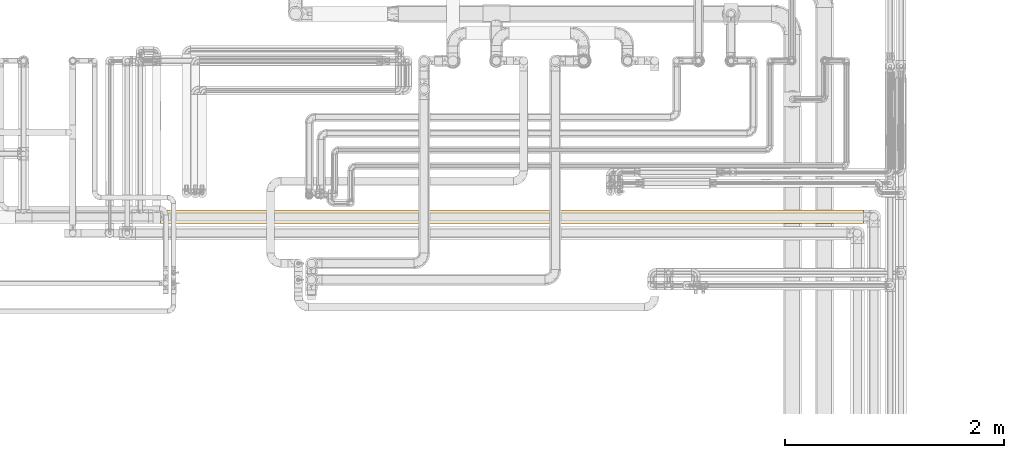
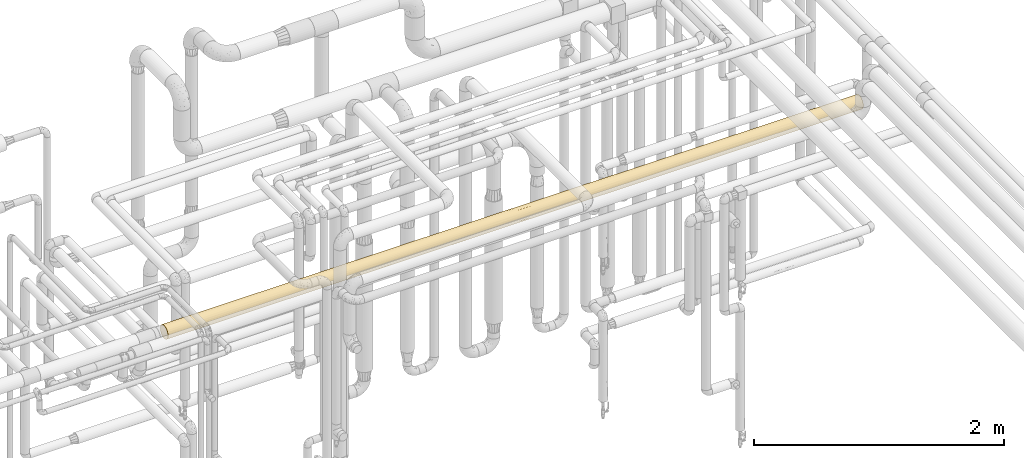
# One storey, part 47 of 827: 1 covering.
"""IFC2X3 building model written with IfcOpenShell, lengths in millimetres."""

from ifc_helpers import new_model, entity, si_unit, converted_unit, derived_unit, direction, frame, origin, place, context, subcontext, project, spatial, faceted_brep, element, save


model = new_model("IFC2X3")

# Units and contexts
model_context = context("Model", 3, precision=0.01, world=origin(), true_north=direction((6.12303176911189e-17, 1.0)))
body_context = subcontext(model_context, "Body", "Model", "MODEL_VIEW")
ifc_project = project(units=[si_unit("LENGTHUNIT", "METRE", prefix="MILLI"), si_unit("AREAUNIT", "SQUARE_METRE"), si_unit("VOLUMEUNIT", "CUBIC_METRE"), converted_unit("PLANEANGLEUNIT", "DEGREE", entity("IfcRatioMeasure", 0.0174532925199433), si_unit("PLANEANGLEUNIT", "RADIAN"), dimensions=[0, 0, 0, 0, 0, 0, 0]), si_unit("MASSUNIT", "GRAM", prefix="KILO"), derived_unit("MASSDENSITYUNIT", [(si_unit("MASSUNIT", "GRAM", prefix="KILO"), 1), (si_unit("LENGTHUNIT", "METRE"), -3)]), derived_unit("MOMENTOFINERTIAUNIT", [(si_unit("LENGTHUNIT", "METRE"), 4)]), si_unit("TIMEUNIT", "SECOND"), si_unit("FREQUENCYUNIT", "HERTZ"), si_unit("THERMODYNAMICTEMPERATUREUNIT", "DEGREE_CELSIUS"), derived_unit("THERMALTRANSMITTANCEUNIT", [(si_unit("MASSUNIT", "GRAM", prefix="KILO"), 1), (si_unit("THERMODYNAMICTEMPERATUREUNIT", "KELVIN"), -1), (si_unit("TIMEUNIT", "SECOND"), -3)]), derived_unit("VOLUMETRICFLOWRATEUNIT", [(si_unit("LENGTHUNIT", "METRE"), 3), (si_unit("TIMEUNIT", "SECOND"), -1)]), derived_unit("MASSFLOWRATEUNIT", [(si_unit("MASSUNIT", "GRAM", prefix="KILO"), 1), (si_unit("TIMEUNIT", "SECOND"), -1)]), derived_unit("ROTATIONALFREQUENCYUNIT", [(si_unit("TIMEUNIT", "SECOND"), -1)]), si_unit("ELECTRICCURRENTUNIT", "AMPERE"), si_unit("ELECTRICVOLTAGEUNIT", "VOLT"), si_unit("POWERUNIT", "WATT"), si_unit("FORCEUNIT", "NEWTON", prefix="KILO"), si_unit("ILLUMINANCEUNIT", "LUX"), si_unit("LUMINOUSFLUXUNIT", "LUMEN"), si_unit("LUMINOUSINTENSITYUNIT", "CANDELA"), derived_unit("USERDEFINED", [(si_unit("MASSUNIT", "GRAM", prefix="KILO"), -1), (si_unit("LENGTHUNIT", "METRE"), -2), (si_unit("TIMEUNIT", "SECOND"), 3), (si_unit("LUMINOUSFLUXUNIT", "LUMEN"), 1)]), derived_unit("LINEARVELOCITYUNIT", [(si_unit("LENGTHUNIT", "METRE"), 1), (si_unit("TIMEUNIT", "SECOND"), -1)]), si_unit("PRESSUREUNIT", "PASCAL"), derived_unit("USERDEFINED", [(si_unit("LENGTHUNIT", "METRE"), -2), (si_unit("MASSUNIT", "GRAM", prefix="KILO"), 1), (si_unit("TIMEUNIT", "SECOND"), -2)]), derived_unit("LINEARFORCEUNIT", [(si_unit("MASSUNIT", "GRAM", prefix="KILO"), 1), (si_unit("LENGTHUNIT", "METRE"), 1), (si_unit("TIMEUNIT", "SECOND"), -2), (si_unit("LENGTHUNIT", "METRE"), -1)]), derived_unit("PLANARFORCEUNIT", [(si_unit("MASSUNIT", "GRAM", prefix="KILO"), 1), (si_unit("LENGTHUNIT", "METRE"), 1), (si_unit("TIMEUNIT", "SECOND"), -2), (si_unit("LENGTHUNIT", "METRE"), -2)])], contexts=[model_context])

# Site, building, storey
site_placement = place(None, origin())
site = spatial("IfcSite", under=ifc_project, at=site_placement, CompositionType="ELEMENT")
building_placement = place(site_placement, origin())
building = spatial("IfcBuilding", under=site, at=building_placement, CompositionType="ELEMENT")
storey_placement = place(building_placement, frame((0.0, 0.0, 28200.0)))
storey = spatial("IfcBuildingStorey", under=building, at=storey_placement, Name="08", CompositionType="ELEMENT", Elevation=28200.0)

# Covering
covering_placement = place(storey_placement, frame((54373.19, 16008.03, 2635.69)))
element("IfcCovering", 1, at=covering_placement, inside=storey, Name=":ADSK_", ObjectType=":ADSK_", PredefinedType="INSULATION", context=body_context, shape_type="Brep", body=[
    faceted_brep([(1.6, 10.0, 32.97), (1.6, 3.73, 48.1), (1.6, 1.6, 64.35), (1.6, 3.73, 80.59), (1.6, 10.0, 95.72), (1.6, 19.97, 108.72), (1.6, 32.97, 118.69), (1.6, 48.1, 124.96), (1.6, 64.35, 127.1), (1.6, 78.77, 125.41), (1.6, 92.41, 120.47), (1.6, 104.55, 112.52), (1.6, 114.54, 102.0), (1.6, 121.85, 89.47), (1.6, 121.85, 39.22), (1.6, 114.54, 26.69), (1.6, 104.55, 16.17), (1.6, 92.41, 8.22), (1.6, 78.77, 3.28), (1.6, 64.35, 1.6), (1.6, 48.1, 3.73), (1.6, 32.97, 10.0), (1.6, 19.97, 19.97), (6434.91, 10.0, 32.97), (6434.91, 19.97, 19.97), (6434.91, 32.97, 10.0), (6434.91, 48.1, 3.73), (6434.91, 64.35, 1.6), (6434.91, 80.59, 3.73), (6434.91, 95.72, 10.0), (6434.91, 108.72, 19.97), (6434.91, 118.69, 32.97), (6434.91, 124.96, 48.1), (6434.91, 127.1, 64.35), (6434.91, 124.96, 80.59), (6434.91, 118.69, 95.72), (6434.91, 108.72, 108.72), (6434.91, 95.72, 118.69), (6434.91, 80.59, 124.96), (6434.91, 64.35, 127.1), (6434.91, 48.1, 124.96), (6434.91, 32.97, 118.69), (6434.91, 19.97, 108.72), (6434.91, 10.0, 95.72), (6434.91, 3.73, 80.59), (6434.91, 1.6, 64.35), (6434.91, 3.73, 48.1), (5777.83, 125.93, 52.32), (5881.72, 127.1, 64.35), (6106.79, 126.17, 53.61), (895.79, 125.04, 48.4), (1322.14, 125.45, 50.08), (1225.08, 119.83, 35.04), (4207.69, 119.05, 33.61), (4497.18, 124.21, 45.54), (4562.47, 118.84, 33.23), (5377.73, 125.13, 48.78), (5328.53, 127.1, 64.35), (946.06, 82.43, 4.26), (554.79, 64.35, 1.6), (451.5, 85.73, 5.35), (433.8, 124.09, 45.15), (3.98, 125.77, 51.51), (732.45, 118.56, 32.74), (359.42, 118.31, 32.32), (5981.34, 114.13, 26.15), (5717.62, 122.32, 40.33), (6107.9, 122.32, 40.33), (344.48, 98.66, 11.81), (6126.75, 88.36, 6.37), (5932.96, 64.35, 1.6), (6115.57, 75.6, 2.61), (6058.02, 102.55, 14.56), (1249.59, 96.2, 10.28), (1423.54, 80.29, 3.65), (2443.79, 124.47, 46.39), (2718.7, 127.1, 64.35), (2736.75, 124.46, 46.34), (5159.73, 102.55, 14.56), (4958.41, 89.58, 6.89), (4772.54, 100.72, 13.21), (5776.51, 75.88, 2.66), (4222.15, 127.1, 64.35), (4060.46, 125.08, 48.56), (1107.98, 64.35, 1.6), (439.99, 109.85, 21.14), (1026.22, 111.64, 23.1), (5023.41, 77.06, 2.9), (4929.06, 64.35, 1.6), (4678.09, 77.12, 2.91), (2718.7, 116.76, 29.85), (2352.04, 120.54, 36.42), (2389.33, 79.72, 3.51), (1937.76, 91.3, 7.68), (2423.92, 95.33, 9.78), (4.79, 127.1, 64.35), (557.98, 127.1, 64.35), (5608.87, 106.66, 18.01), (5259.1, 115.22, 27.62), (5351.39, 81.11, 3.88), (5752.1, 88.36, 6.37), (5626.66, 115.84, 28.48), (2000.35, 77.07, 2.9), (1111.17, 127.1, 64.35), (760.89, 98.71, 11.84), (744.88, 108.07, 19.34), (4889.12, 121.29, 37.99), (4812.81, 111.54, 22.99), (5051.94, 127.1, 64.35), (3320.74, 64.35, 1.6), (3044.14, 76.21, 2.73), (3459.03, 75.66, 2.62), (1446.35, 109.85, 21.14), (1725.15, 115.85, 28.5), (3119.65, 88.91, 6.6), (3597.33, 86.6, 5.67), (3597.33, 64.35, 1.6), (2734.01, 103.64, 15.42), (2271.51, 106.98, 18.31), (3199.36, 100.48, 13.05), (3721.0, 107.38, 18.67), (3727.7, 97.2, 10.88), (2217.55, 127.1, 64.35), (2166.37, 125.41, 49.9), (1785.81, 125.65, 50.96), (1570.22, 122.14, 39.91), (1940.96, 121.6, 38.67), (2090.83, 115.14, 27.51), (2399.3, 114.31, 26.38), (5420.83, 94.08, 9.09), (5407.25, 120.89, 37.13), (1610.71, 96.51, 10.47), (1844.18, 105.14, 16.66), (1700.6, 75.81, 2.65), (1660.88, 86.54, 5.65), (4520.44, 91.22, 7.64), (4060.55, 96.67, 10.56), (4416.77, 105.46, 16.94), (4150.52, 79.69, 3.5), (4427.12, 64.35, 1.6), (4222.15, 64.35, 1.6), (3873.93, 64.35, 1.6), (3738.75, 116.68, 29.73), (3377.76, 114.34, 26.42), (1664.36, 127.1, 64.35), (3093.51, 120.98, 37.33), (3522.07, 122.25, 40.16), (3582.7, 125.96, 52.47), (1661.16, 64.35, 1.6), (1384.57, 64.35, 1.6), (5933.76, 127.1, 64.35), (5432.61, 127.1, 64.35), (4775.34, 127.1, 64.35), (4913.64, 125.73, 51.35), (4931.45, 127.1, 64.35), (4430.31, 127.1, 64.35), (3250.33, 125.41, 49.88), (3721.0, 127.1, 64.35), (3877.11, 127.1, 64.35), (5881.72, 64.35, 1.6), (5431.01, 64.35, 1.6), (4775.34, 64.35, 1.6), (5328.53, 64.35, 1.6), (3789.26, 76.61, 2.81), (3720.2, 64.35, 1.6), (4072.32, 107.43, 18.73), (3030.79, 110.4, 21.72), (2494.14, 127.1, 64.35), (2770.74, 127.1, 64.35), (3219.85, 127.1, 64.35), (3323.93, 127.1, 64.35), (2767.55, 87.89, 6.18), (2697.3, 76.34, 2.75), (2214.35, 64.35, 1.6), (3218.25, 64.35, 1.6), (2767.55, 64.35, 1.6), (2716.3, 64.35, 1.6), (3469.23, 48.39, 3.66), (3927.11, 37.93, 7.43), (3386.63, 31.41, 10.93), (2319.13, 6.07, 41.06), (2400.68, 13.08, 28.16), (2722.51, 10.74, 31.73), (2136.84, 37.89, 7.45), (1841.45, 33.43, 9.74), (1937.76, 48.83, 3.54), (5981.34, 14.56, 26.15), (6058.02, 26.15, 14.56), (4309.01, 45.35, 4.54), (4743.24, 45.56, 4.47), (4932.91, 29.66, 12.05), (5389.41, 26.15, 14.56), (5061.8, 16.65, 23.57), (5881.72, 1.6, 64.35), (6106.79, 2.52, 53.61), (6107.9, 6.37, 40.33), (5777.83, 2.76, 52.32), (328.6, 40.33, 6.37), (5723.71, 29.27, 12.32), (5523.77, 14.29, 26.5), (503.54, 1.6, 64.35), (497.08, 3.02, 51.07), (854.14, 2.84, 51.93), (309.76, 6.37, 40.33), (6101.81, 53.36, 2.56), (5768.98, 52.3, 2.76), (4944.26, 3.32, 49.73), (5328.53, 1.6, 64.35), (4775.34, 1.6, 64.35), (455.16, 26.15, 14.56), (329.72, 53.61, 2.52), (6179.58, 40.33, 6.37), (1319.82, 28.4, 12.91), (965.48, 25.5, 15.06), (1043.86, 36.39, 8.17), (658.68, 52.32, 2.76), (718.89, 40.33, 6.37), (1058.77, 48.78, 3.56), (1276.78, 14.56, 26.15), (1588.01, 7.39, 38.0), (1113.63, 6.8, 39.33), (876.51, 13.0, 28.27), (378.49, 14.56, 26.15), (5246.57, 6.86, 39.18), (4784.6, 8.47, 35.78), (1005.49, 1.6, 64.35), (554.78, 1.6, 64.35), (5571.77, 44.14, 4.94), (5276.97, 44.0, 4.98), (3763.99, 26.35, 14.4), (4097.67, 20.62, 19.34), (3738.13, 11.86, 29.95), (4250.11, 8.83, 35.09), (3877.02, 4.3, 46.12), (5717.62, 6.37, 40.33), (5847.04, 40.33, 6.37), (1522.87, 51.35, 2.96), (2713.99, 5.14, 43.57), (3439.03, 20.23, 19.72), (4169.4, 2.85, 51.86), (3668.96, 1.6, 64.35), (684.4, 6.37, 40.33), (4465.28, 31.2, 11.06), (4594.16, 17.86, 22.19), (5279.25, 2.92, 51.53), (4498.75, 3.05, 50.93), (3392.37, 4.47, 45.56), (3202.52, 13.04, 28.21), (3070.63, 21.92, 18.11), (2716.3, 18.67, 21.31), (2392.23, 21.79, 18.23), (2802.55, 29.82, 11.95), (3960.86, 52.33, 2.76), (3040.71, 3.18, 50.33), (3115.77, 1.6, 64.35), (3218.25, 1.6, 64.35), (1956.79, 3.95, 47.32), (2424.28, 2.68, 52.74), (1507.44, 1.6, 64.35), (1235.98, 2.69, 52.65), (1591.0, 3.02, 51.04), (2025.77, 10.78, 31.65), (2099.75, 18.06, 21.98), (1647.58, 22.63, 17.47), (2103.35, 27.32, 13.68), (1707.73, 13.77, 27.2), (2590.66, 53.45, 2.55), (3017.79, 7.46, 37.86), (2706.57, 42.74, 5.43), (2431.36, 33.56, 9.67), (2330.02, 47.11, 4.01), (4222.15, 1.6, 64.35), (1547.38, 37.99, 7.4), (1384.57, 1.6, 64.35), (1107.98, 1.6, 64.35), (2562.58, 1.6, 64.35), (2009.39, 1.6, 64.35), (1661.16, 1.6, 64.35), (2285.98, 1.6, 64.35), (2214.35, 1.6, 64.35), (2983.28, 52.67, 2.69), (3074.07, 38.93, 6.97), (2716.3, 1.6, 64.35), (3720.2, 1.6, 64.35), (5981.34, 26.15, 114.13), (6058.02, 14.56, 102.55), (718.89, 6.37, 88.36), (658.68, 2.76, 76.38), (1058.77, 3.56, 79.91), (4944.26, 49.73, 125.37), (5328.53, 64.35, 127.1), (5051.94, 64.35, 127.1), (4775.34, 64.35, 127.1), (3469.23, 3.66, 80.3), (3927.11, 7.43, 90.76), (3386.63, 10.93, 97.28), (2136.84, 7.45, 90.8), (1841.45, 9.74, 95.26), (1937.76, 3.54, 79.86), (6107.9, 40.33, 122.32), (2319.13, 41.06, 122.62), (2400.68, 28.16, 115.61), (2722.51, 31.73, 117.95), (6106.79, 53.61, 126.17), (5777.83, 52.32, 125.93), (4932.91, 12.05, 99.03), (5389.41, 14.56, 102.55), (5061.8, 23.57, 112.04), (5723.71, 12.32, 99.42), (5523.77, 26.5, 114.4), (503.54, 64.35, 127.1), (497.08, 51.07, 125.67), (854.14, 51.93, 125.85), (309.76, 40.33, 122.32), (328.6, 6.37, 88.36), (455.16, 14.56, 102.55), (1276.78, 26.15, 114.13), (1588.01, 38.0, 121.3), (1113.63, 39.33, 121.9), (329.72, 2.52, 75.09), (6179.58, 6.37, 88.36), (4309.01, 4.54, 83.34), (4743.24, 4.47, 83.13), (5881.72, 64.35, 127.1), (1319.82, 12.91, 100.29), (965.48, 15.06, 103.19), (1043.86, 8.17, 92.3), (6101.81, 2.56, 75.33), (5768.98, 2.76, 76.39), (876.51, 28.27, 115.69), (378.49, 26.15, 114.13), (5246.57, 39.18, 121.83), (4784.6, 35.78, 120.22), (1005.49, 64.35, 127.1), (554.79, 64.35, 127.1), (5571.77, 4.94, 84.55), (5276.97, 4.98, 84.69), (3763.99, 14.4, 102.34), (4097.67, 19.34, 108.07), (3738.13, 29.95, 116.83), (4250.11, 35.09, 119.86), (3877.02, 46.12, 124.39), (5717.62, 40.33, 122.32), (5847.04, 6.37, 88.36), (1522.87, 2.96, 77.34), (2713.99, 43.57, 123.56), (3439.03, 19.72, 108.46), (4169.4, 51.86, 125.84), (3668.96, 64.35, 127.1), (684.4, 40.33, 122.32), (4465.28, 11.06, 97.49), (4594.16, 22.19, 110.83), (5279.25, 51.53, 125.77), (4498.75, 50.93, 125.64), (3392.37, 45.56, 124.22), (3202.52, 28.21, 115.65), (3070.63, 18.11, 106.77), (2716.3, 21.31, 110.02), (2392.23, 18.23, 106.9), (2802.55, 11.95, 98.87), (3960.86, 2.76, 76.36), (3040.71, 50.33, 125.51), (3115.77, 64.35, 127.1), (3218.25, 64.35, 127.1), (1956.79, 47.32, 124.74), (2424.28, 52.74, 126.01), (1507.44, 64.35, 127.1), (1235.98, 52.65, 126.0), (1591.0, 51.04, 125.67), (2025.77, 31.65, 117.91), (2099.75, 21.98, 110.63), (1647.58, 17.47, 106.06), (2103.35, 13.68, 101.37), (1707.73, 27.2, 114.92), (2590.66, 2.55, 75.24), (3017.79, 37.86, 121.23), (2706.57, 5.43, 85.95), (2431.36, 9.67, 95.13), (2330.02, 4.01, 81.58), (4222.15, 64.35, 127.1), (1547.38, 7.4, 90.7), (1107.97, 64.35, 127.1), (2562.58, 64.35, 127.1), (2009.39, 64.35, 127.1), (1661.16, 64.35, 127.1), (2285.98, 64.35, 127.1), (2214.35, 64.35, 127.1), (2983.28, 2.69, 76.03), (3074.07, 6.97, 89.76), (2716.3, 64.35, 127.1), (3720.2, 64.35, 127.1), (5777.83, 76.38, 125.93), (5377.73, 79.91, 125.13), (5024.71, 125.8, 77.02), (4680.89, 125.78, 77.13), (451.5, 85.73, 123.34), (6106.79, 75.09, 126.17), (4057.32, 80.16, 125.07), (4496.17, 83.15, 124.21), (6107.9, 88.36, 122.32), (5981.34, 102.55, 114.13), (5717.62, 88.36, 122.32), (1225.08, 119.83, 93.65), (1026.22, 111.64, 105.59), (1446.35, 109.85, 107.55), (3.98, 125.77, 77.18), (344.48, 98.66, 116.88), (6058.02, 114.13, 102.55), (6127.03, 122.32, 88.36), (946.06, 82.43, 124.43), (760.89, 98.71, 116.85), (5160.89, 114.13, 102.55), (4959.88, 121.79, 89.59), (4773.68, 115.48, 100.71), (6115.69, 126.08, 75.61), (5776.43, 126.03, 75.87), (439.99, 109.85, 107.55), (727.91, 111.88, 105.3), (359.42, 118.31, 96.37), (732.45, 118.56, 95.95), (433.8, 124.09, 83.54), (1937.76, 91.3, 121.01), (1610.61, 96.5, 118.23), (1805.94, 78.07, 125.58), (4888.83, 90.71, 121.29), (4813.54, 105.72, 111.53), (4571.62, 97.09, 117.87), (895.79, 125.04, 80.29), (2947.85, 81.99, 124.56), (3357.39, 76.9, 125.83), (3220.4, 86.96, 122.88), (2415.15, 84.48, 123.78), (2716.3, 98.88, 116.74), (5609.45, 110.68, 106.66), (5259.61, 101.06, 115.23), (5350.53, 124.81, 81.13), (5752.62, 122.32, 88.36), (5626.75, 100.21, 115.84), (1785.81, 125.65, 77.73), (2166.37, 125.41, 78.79), (1940.96, 121.6, 90.02), (1570.22, 122.14, 88.78), (1725.15, 115.85, 100.19), (2211.56, 100.64, 115.53), (1423.54, 80.29, 125.04), (1249.59, 96.2, 118.41), (2042.33, 115.91, 100.1), (1322.14, 125.45, 78.61), (3048.58, 125.95, 76.3), (3384.59, 125.8, 77.02), (3707.83, 126.17, 75.09), (2356.13, 120.49, 92.37), (3200.95, 115.73, 100.36), (3720.2, 110.04, 107.35), (3729.11, 117.82, 97.18), (5421.61, 119.6, 94.08), (5407.44, 91.55, 120.89), (1846.8, 105.05, 112.1), (4522.39, 121.05, 91.21), (4061.61, 118.14, 96.66), (4417.92, 111.77, 105.43), (4153.72, 125.2, 79.66), (3941.65, 102.36, 114.27), (3617.28, 101.06, 115.23), (3296.3, 102.99, 113.78), (3712.92, 77.75, 125.65), (3119.12, 122.09, 88.91), (3600.53, 123.03, 86.57), (4913.64, 77.35, 125.73), (4207.68, 95.13, 119.02), (3870.56, 91.15, 121.08), (4034.5, 110.92, 106.4), (2750.32, 113.78, 102.99), (2300.8, 111.56, 105.68), (2964.7, 106.46, 110.86), (2632.44, 125.95, 76.26), (2770.74, 122.57, 87.74), (2107.7, 81.67, 124.66), (3037.49, 96.54, 118.21), (3521.81, 88.53, 122.25)], [[[0, 1, 2, 3, 4, 5, 6, 7, 8, 9, 10, 11, 12, 13, 14, 15, 16, 17, 18, 19, 20, 21, 22]], [[23, 24, 25, 26, 27, 28, 29, 30, 31, 32, 33, 34, 35, 36, 37, 38, 39, 40, 41, 42, 43, 44, 45, 46]], [[47, 48, 49]], [[50, 51, 52]], [[53, 54, 55]], [[56, 57, 47]], [[58, 59, 60]], [[61, 14, 62]], [[61, 63, 64]], [[65, 66, 67]], [[61, 64, 14]], [[17, 68, 60]], [[69, 29, 28]], [[27, 70, 71]], [[67, 32, 31]], [[72, 65, 30]], [[58, 73, 74]], [[75, 76, 77]], [[78, 79, 80]], [[69, 71, 81]], [[60, 18, 17]], [[82, 54, 83]], [[59, 58, 84]], [[63, 85, 64]], [[52, 86, 63]], [[49, 32, 67]], [[87, 88, 89]], [[77, 90, 91]], [[92, 93, 94]], [[52, 63, 50]], [[16, 15, 85]], [[62, 95, 96]], [[63, 61, 50]], [[65, 31, 30]], [[97, 78, 98]], [[99, 100, 81]], [[65, 97, 101]], [[68, 16, 85]], [[59, 19, 18]], [[93, 92, 102]], [[62, 96, 61]], [[50, 96, 103]], [[60, 104, 58]], [[59, 18, 60]], [[105, 63, 86]], [[68, 104, 60]], [[72, 30, 29]], [[32, 49, 33]], [[65, 72, 97]], [[106, 98, 107]], [[69, 81, 100]], [[57, 56, 108]], [[109, 110, 111]], [[52, 112, 86]], [[73, 104, 86]], [[74, 84, 58]], [[58, 104, 73]], [[52, 113, 112]], [[111, 114, 115]], [[116, 109, 111]], [[117, 94, 118]], [[119, 120, 121]], [[96, 50, 61]], [[122, 123, 124]], [[52, 51, 125]], [[123, 126, 124]], [[127, 91, 128]], [[50, 103, 51]], [[52, 125, 113]], [[69, 72, 29]], [[100, 129, 97]], [[100, 97, 72]], [[107, 98, 78]], [[130, 106, 56]], [[65, 101, 66]], [[131, 112, 132]], [[133, 134, 102]], [[135, 79, 89]], [[136, 137, 135]], [[138, 139, 140, 141]], [[107, 80, 137]], [[142, 120, 143]], [[103, 144, 51]], [[143, 145, 146]], [[147, 83, 146]], [[73, 131, 134]], [[74, 148, 149, 84]], [[111, 110, 114]], [[135, 89, 138]], [[138, 136, 135]], [[65, 67, 31]], [[47, 49, 67]], [[47, 67, 66]], [[49, 48, 150, 33]], [[56, 47, 66]], [[47, 57, 151, 48]], [[130, 56, 66]], [[152, 153, 54]], [[106, 54, 153]], [[153, 56, 106]], [[125, 124, 126]], [[56, 153, 108]], [[153, 152, 154, 108]], [[55, 54, 106]], [[83, 54, 53]], [[54, 82, 155, 152]], [[142, 83, 53]], [[71, 69, 28]], [[146, 156, 147]], [[83, 157, 158, 82]], [[72, 69, 100]], [[27, 71, 28]], [[71, 70, 81]], [[81, 70, 159, 160]], [[99, 81, 160]], [[89, 88, 161, 139]], [[129, 100, 99]], [[87, 160, 162, 88]], [[163, 141, 164, 116]], [[121, 120, 165]], [[136, 138, 163]], [[136, 165, 137]], [[136, 121, 165]], [[55, 137, 53]], [[119, 114, 117]], [[145, 143, 166]], [[124, 51, 144]], [[125, 126, 113]], [[51, 124, 125]], [[122, 124, 144]], [[75, 122, 167, 76]], [[91, 126, 123]], [[77, 145, 90]], [[91, 123, 75]], [[127, 128, 118]], [[119, 166, 143]], [[132, 112, 113]], [[156, 76, 168, 169]], [[145, 156, 146]], [[126, 127, 113]], [[113, 127, 132]], [[118, 93, 132]], [[131, 132, 93]], [[91, 127, 126]], [[132, 127, 118]], [[77, 76, 156]], [[142, 143, 146]], [[120, 119, 143]], [[119, 117, 166]], [[77, 156, 145]], [[147, 169, 170, 157]], [[169, 147, 156]], [[83, 147, 157]], [[73, 86, 112]], [[105, 104, 68]], [[83, 142, 146]], [[165, 142, 53]], [[91, 90, 128]], [[117, 128, 90]], [[138, 89, 139]], [[80, 79, 135]], [[129, 79, 78]], [[87, 79, 99]], [[137, 80, 135]], [[78, 80, 107]], [[94, 117, 171]], [[117, 118, 128]], [[94, 171, 92]], [[93, 118, 94]], [[172, 173, 92]], [[172, 92, 171]], [[92, 173, 102]], [[173, 148, 102]], [[133, 102, 148]], [[79, 129, 99]], [[97, 129, 78]], [[79, 87, 89]], [[160, 87, 99]], [[134, 133, 74]], [[112, 131, 73]], [[85, 15, 64]], [[14, 64, 15]], [[16, 68, 17]], [[68, 85, 105]], [[106, 107, 55]], [[137, 55, 107]], [[117, 90, 166]], [[145, 166, 90]], [[97, 98, 101]], [[130, 101, 98]], [[116, 111, 163]], [[110, 109, 174, 175]], [[111, 115, 163]], [[172, 110, 175]], [[114, 110, 171]], [[136, 163, 115]], [[138, 141, 163]], [[117, 114, 171]], [[115, 114, 119]], [[101, 130, 66]], [[106, 130, 98]], [[136, 115, 121]], [[119, 121, 115]], [[142, 165, 120]], [[53, 137, 165]], [[75, 123, 122]], [[77, 91, 75]], [[63, 105, 85]], [[86, 104, 105]], [[110, 172, 171]], [[172, 175, 176, 173]], [[148, 74, 133]], [[73, 134, 74]], [[131, 93, 134]], [[102, 134, 93]], [[177, 178, 179]], [[180, 181, 182]], [[183, 184, 185]], [[186, 187, 24]], [[188, 161, 189]], [[190, 191, 192]], [[45, 193, 194]], [[25, 24, 187]], [[195, 194, 196]], [[20, 197, 21]], [[191, 198, 199]], [[200, 201, 202]], [[203, 201, 1]], [[159, 204, 205]], [[206, 207, 208]], [[209, 22, 21]], [[19, 59, 210]], [[211, 26, 25]], [[212, 213, 214]], [[1, 0, 203]], [[197, 210, 215]], [[21, 197, 209]], [[23, 195, 186]], [[195, 23, 46]], [[216, 215, 217]], [[218, 219, 220]], [[221, 222, 209]], [[223, 224, 192]], [[23, 186, 24]], [[222, 22, 209]], [[202, 225, 226, 200]], [[227, 191, 228]], [[26, 211, 204]], [[229, 178, 230]], [[231, 232, 233]], [[232, 231, 230]], [[199, 192, 191]], [[213, 209, 216]], [[197, 215, 216]], [[22, 222, 0]], [[199, 186, 234]], [[195, 196, 234]], [[187, 198, 235]], [[217, 84, 149]], [[1, 201, 2]], [[185, 236, 148]], [[237, 180, 182]], [[231, 238, 229]], [[239, 240, 233]], [[26, 204, 27]], [[216, 217, 214]], [[221, 218, 220]], [[221, 209, 213]], [[203, 222, 241]], [[186, 195, 234]], [[186, 199, 198]], [[211, 187, 235]], [[209, 197, 216]], [[242, 190, 243]], [[242, 243, 230]], [[210, 197, 20]], [[194, 195, 46]], [[223, 199, 234]], [[199, 223, 192]], [[244, 234, 196]], [[223, 206, 224]], [[243, 192, 224]], [[208, 245, 206]], [[192, 243, 190]], [[232, 243, 224]], [[243, 232, 230]], [[224, 206, 245]], [[246, 231, 233]], [[247, 248, 238]], [[178, 242, 230]], [[249, 250, 251]], [[188, 252, 140]], [[177, 174, 109, 116, 164]], [[242, 189, 190]], [[253, 246, 254]], [[246, 240, 255, 254]], [[247, 231, 246]], [[256, 180, 257]], [[258, 259, 260]], [[256, 261, 180]], [[262, 263, 264]], [[189, 242, 188]], [[228, 191, 190]], [[228, 190, 189]], [[228, 161, 88, 162]], [[205, 162, 160, 159]], [[242, 178, 188]], [[228, 189, 161]], [[265, 262, 261]], [[176, 266, 173]], [[246, 253, 267]], [[249, 251, 248]], [[19, 210, 20]], [[210, 59, 215]], [[45, 194, 46]], [[194, 193, 196]], [[59, 84, 215]], [[217, 215, 84]], [[236, 149, 148]], [[216, 214, 213]], [[268, 269, 270]], [[185, 148, 173]], [[250, 269, 251]], [[269, 264, 183]], [[181, 250, 249]], [[193, 207, 196]], [[196, 207, 244]], [[232, 245, 239]], [[240, 246, 233]], [[244, 206, 223]], [[208, 271, 245]], [[239, 245, 271]], [[224, 245, 232]], [[236, 185, 272]], [[149, 236, 217]], [[217, 236, 272]], [[222, 203, 0]], [[201, 203, 241]], [[201, 241, 202]], [[201, 200, 2]], [[220, 241, 221]], [[259, 202, 220]], [[220, 202, 241]], [[263, 265, 218]], [[202, 259, 225]], [[256, 219, 261]], [[219, 260, 259]], [[219, 259, 220]], [[259, 258, 273, 274, 225]], [[222, 221, 241]], [[213, 218, 221]], [[253, 275, 237]], [[260, 276, 277, 258]], [[181, 180, 261]], [[257, 275, 278]], [[256, 257, 278]], [[250, 262, 264]], [[181, 249, 182]], [[257, 237, 275]], [[256, 278, 279, 276]], [[237, 257, 180]], [[280, 177, 281]], [[177, 164, 252]], [[179, 248, 281]], [[262, 181, 261]], [[269, 250, 264]], [[269, 183, 270]], [[269, 268, 251]], [[185, 173, 270]], [[270, 266, 268]], [[281, 251, 268]], [[280, 176, 175, 174]], [[249, 248, 247]], [[280, 281, 268]], [[177, 179, 281]], [[280, 268, 266]], [[177, 280, 174]], [[281, 248, 251]], [[238, 248, 179]], [[179, 178, 229]], [[231, 247, 238]], [[181, 262, 250]], [[261, 219, 265]], [[212, 218, 213]], [[184, 263, 272]], [[252, 188, 178]], [[188, 140, 139, 161]], [[177, 252, 178]], [[252, 164, 141, 140]], [[219, 256, 260]], [[276, 260, 256]], [[249, 247, 182]], [[267, 182, 247]], [[184, 183, 264]], [[185, 270, 183]], [[263, 184, 264]], [[185, 184, 272]], [[217, 272, 214]], [[212, 214, 272]], [[272, 263, 212]], [[218, 212, 263]], [[244, 223, 234]], [[207, 206, 244]], [[187, 211, 25]], [[235, 205, 204]], [[235, 204, 211]], [[204, 159, 70, 27]], [[235, 227, 205]], [[205, 227, 162]], [[227, 235, 198]], [[162, 227, 228]], [[198, 187, 186]], [[227, 198, 191]], [[253, 254, 282, 275]], [[267, 253, 237]], [[182, 267, 237]], [[246, 267, 247]], [[239, 271, 283, 240]], [[232, 239, 233]], [[173, 266, 270]], [[280, 266, 176]], [[231, 229, 230]], [[179, 229, 238]], [[218, 265, 219]], [[262, 265, 263]], [[284, 285, 42]], [[286, 287, 288]], [[289, 290, 291, 292]], [[293, 294, 295]], [[296, 297, 298]], [[42, 285, 43]], [[299, 41, 40]], [[300, 301, 302]], [[299, 303, 304]], [[305, 306, 307]], [[306, 308, 309]], [[310, 311, 312]], [[313, 311, 7]], [[4, 314, 315]], [[316, 317, 318]], [[315, 5, 4]], [[319, 2, 200, 226]], [[320, 44, 43]], [[3, 314, 4]], [[7, 6, 313]], [[314, 319, 287]], [[321, 208, 322]], [[39, 323, 303]], [[324, 325, 326]], [[41, 299, 284]], [[193, 327, 328]], [[329, 330, 315]], [[331, 332, 307]], [[41, 284, 42]], [[330, 5, 315]], [[312, 333, 334, 310]], [[335, 306, 336]], [[44, 320, 327]], [[337, 294, 338]], [[339, 340, 341]], [[340, 339, 338]], [[309, 307, 306]], [[325, 315, 286]], [[314, 287, 286]], [[5, 330, 6]], [[309, 284, 342]], [[299, 304, 342]], [[285, 308, 343]], [[288, 274, 273]], [[7, 311, 8]], [[298, 344, 277]], [[345, 300, 302]], [[339, 346, 337]], [[347, 348, 341]], [[44, 327, 45]], [[286, 288, 326]], [[329, 316, 318]], [[329, 315, 325]], [[313, 330, 349]], [[284, 299, 342]], [[284, 309, 308]], [[320, 285, 343]], [[350, 305, 351]], [[350, 351, 338]], [[319, 314, 3]], [[315, 314, 286]], [[303, 299, 40]], [[331, 309, 342]], [[309, 331, 307]], [[352, 342, 304]], [[331, 289, 332]], [[351, 307, 332]], [[292, 353, 289]], [[307, 351, 305]], [[340, 351, 332]], [[351, 340, 338]], [[332, 289, 353]], [[354, 339, 341]], [[355, 356, 346]], [[294, 350, 338]], [[357, 358, 359]], [[321, 360, 271]], [[293, 255, 240, 283]], [[350, 322, 305]], [[361, 354, 362]], [[354, 348, 363, 362]], [[355, 339, 354]], [[364, 300, 365]], [[366, 367, 368]], [[364, 369, 300]], [[370, 371, 372]], [[322, 350, 321]], [[336, 306, 305]], [[336, 305, 322]], [[336, 208, 207]], [[207, 193, 328]], [[350, 294, 321]], [[336, 322, 208]], [[373, 370, 369]], [[374, 279, 278, 275, 282]], [[354, 361, 375]], [[357, 359, 356]], [[2, 319, 3]], [[319, 226, 287]], [[39, 303, 40]], [[303, 323, 304]], [[287, 226, 225, 274]], [[288, 287, 274]], [[344, 273, 258, 277]], [[286, 326, 325]], [[376, 377, 378]], [[298, 277, 276, 279]], [[358, 377, 359]], [[377, 372, 296]], [[301, 358, 357]], [[323, 290, 304]], [[304, 290, 352]], [[340, 353, 347]], [[348, 354, 341]], [[352, 289, 331]], [[292, 379, 353]], [[347, 353, 379]], [[332, 353, 340]], [[344, 298, 380]], [[273, 344, 288]], [[288, 344, 380]], [[330, 313, 6]], [[311, 313, 349]], [[311, 349, 312]], [[311, 310, 8]], [[318, 349, 329]], [[367, 312, 318]], [[318, 312, 349]], [[371, 373, 316]], [[312, 367, 333]], [[364, 317, 369]], [[317, 368, 367]], [[317, 367, 318]], [[367, 366, 381, 333]], [[330, 329, 349]], [[325, 316, 329]], [[361, 382, 345]], [[368, 383, 384, 366]], [[301, 300, 369]], [[365, 382, 385]], [[364, 365, 385]], [[358, 370, 372]], [[301, 357, 302]], [[365, 345, 382]], [[364, 385, 386, 383]], [[345, 365, 300]], [[387, 293, 388]], [[293, 283, 360]], [[295, 356, 388]], [[370, 301, 369]], [[377, 358, 372]], [[377, 296, 378]], [[377, 376, 359]], [[298, 279, 378]], [[378, 374, 376]], [[388, 359, 376]], [[387, 282, 254, 255]], [[357, 356, 355]], [[387, 388, 376]], [[293, 295, 388]], [[387, 376, 374]], [[293, 387, 255]], [[388, 356, 359]], [[346, 356, 295]], [[295, 294, 337]], [[339, 355, 346]], [[301, 370, 358]], [[369, 317, 373]], [[324, 316, 325]], [[297, 371, 380]], [[360, 321, 294]], [[208, 321, 271]], [[293, 360, 294]], [[271, 360, 283]], [[317, 364, 368]], [[383, 368, 364]], [[357, 355, 302]], [[375, 302, 355]], [[297, 296, 372]], [[298, 378, 296]], [[371, 297, 372]], [[298, 297, 380]], [[288, 380, 326]], [[324, 326, 380]], [[380, 371, 324]], [[316, 324, 371]], [[352, 331, 342]], [[290, 289, 352]], [[285, 320, 43]], [[343, 328, 327]], [[343, 327, 320]], [[45, 327, 193]], [[343, 335, 328]], [[328, 335, 207]], [[335, 343, 308]], [[207, 335, 336]], [[308, 285, 284]], [[335, 308, 306]], [[361, 362, 389, 382]], [[375, 361, 345]], [[302, 375, 345]], [[354, 375, 355]], [[347, 379, 390, 348]], [[340, 347, 341]], [[279, 374, 378]], [[387, 374, 282]], [[339, 337, 338]], [[295, 337, 346]], [[316, 373, 317]], [[370, 373, 371]], [[391, 392, 290]], [[393, 154, 394]], [[10, 9, 395]], [[391, 323, 396]], [[397, 379, 398]], [[399, 400, 401]], [[402, 403, 404]], [[405, 96, 95]], [[10, 395, 406]], [[407, 400, 36]], [[408, 35, 34]], [[409, 410, 395]], [[399, 38, 37]], [[411, 412, 413]], [[408, 414, 415]], [[406, 410, 416]], [[417, 418, 416]], [[419, 420, 418]], [[12, 418, 13]], [[421, 422, 423]], [[424, 425, 426]], [[403, 402, 419]], [[402, 427, 419]], [[428, 429, 430]], [[33, 150, 414]], [[431, 428, 432]], [[396, 38, 399]], [[395, 334, 409]], [[416, 12, 11]], [[427, 96, 420]], [[13, 420, 405]], [[400, 37, 36]], [[433, 411, 434]], [[435, 436, 415]], [[400, 433, 437]], [[9, 8, 310, 334]], [[438, 439, 122]], [[440, 441, 442]], [[427, 420, 419]], [[96, 405, 420]], [[9, 334, 395]], [[409, 334, 333, 381]], [[11, 10, 406]], [[417, 410, 403]], [[407, 36, 35]], [[38, 396, 39]], [[400, 407, 433]], [[424, 434, 425]], [[408, 415, 436]], [[290, 392, 291]], [[439, 167, 122]], [[432, 443, 431]], [[444, 381, 366, 384]], [[410, 409, 445]], [[403, 445, 404]], [[423, 422, 444]], [[442, 446, 440]], [[447, 103, 427]], [[96, 427, 103]], [[438, 122, 144]], [[402, 447, 427]], [[448, 170, 169, 168]], [[170, 449, 450]], [[439, 440, 451]], [[452, 453, 454]], [[402, 442, 441]], [[438, 447, 441]], [[408, 407, 35]], [[436, 455, 433]], [[436, 433, 407]], [[425, 434, 411]], [[456, 424, 392]], [[400, 437, 401]], [[444, 445, 409]], [[457, 422, 421]], [[458, 412, 394]], [[459, 460, 458]], [[461, 155, 82, 158]], [[425, 413, 460]], [[462, 453, 463]], [[441, 447, 402]], [[453, 452, 464]], [[465, 390, 397]], [[381, 444, 409]], [[444, 384, 423]], [[449, 466, 467]], [[458, 394, 461]], [[461, 459, 458]], [[400, 399, 37]], [[391, 396, 399]], [[391, 399, 401]], [[39, 396, 323]], [[392, 391, 401]], [[290, 323, 391]], [[456, 392, 401]], [[292, 468, 398]], [[424, 398, 468]], [[468, 392, 424]], [[144, 103, 447]], [[392, 468, 291]], [[292, 291, 468]], [[426, 398, 424]], [[397, 398, 469]], [[292, 398, 379]], [[469, 470, 397]], [[414, 408, 34]], [[429, 390, 465]], [[390, 379, 397]], [[407, 408, 436]], [[33, 414, 34]], [[414, 150, 415]], [[415, 150, 48, 151]], [[435, 415, 151]], [[394, 154, 152, 155]], [[455, 436, 435]], [[393, 151, 57, 108, 154]], [[450, 461, 158]], [[454, 453, 471]], [[467, 459, 461]], [[459, 454, 471]], [[471, 453, 462]], [[426, 460, 469]], [[452, 466, 472]], [[470, 462, 463]], [[442, 402, 404]], [[438, 441, 440]], [[404, 445, 422]], [[457, 443, 473]], [[457, 442, 404]], [[474, 472, 432]], [[443, 457, 421]], [[446, 457, 473]], [[438, 440, 439]], [[447, 438, 144]], [[440, 446, 451]], [[168, 475, 448]], [[472, 451, 473]], [[475, 439, 451]], [[167, 439, 475]], [[475, 451, 476]], [[476, 448, 475]], [[475, 168, 76, 167]], [[466, 448, 476]], [[449, 170, 448]], [[431, 443, 421]], [[432, 473, 443]], [[423, 477, 421]], [[431, 389, 428]], [[474, 452, 472]], [[429, 363, 348, 390]], [[431, 386, 385, 382, 389]], [[428, 389, 362, 363]], [[478, 428, 430]], [[417, 403, 419]], [[445, 403, 410]], [[457, 446, 442]], [[451, 446, 473]], [[472, 466, 476]], [[467, 466, 452]], [[461, 394, 155]], [[413, 412, 458]], [[455, 412, 411]], [[393, 412, 435]], [[460, 413, 458]], [[411, 413, 425]], [[412, 455, 435]], [[433, 455, 411]], [[404, 422, 457]], [[444, 422, 445]], [[412, 393, 394]], [[151, 393, 435]], [[13, 418, 420]], [[12, 416, 418]], [[423, 384, 383, 386]], [[477, 386, 431]], [[386, 477, 423]], [[431, 421, 477]], [[451, 472, 476]], [[432, 472, 473]], [[466, 449, 448]], [[450, 449, 467]], [[461, 450, 467]], [[450, 158, 157, 170]], [[410, 406, 395]], [[11, 406, 416]], [[462, 470, 469]], [[465, 470, 479]], [[471, 469, 460]], [[463, 453, 464]], [[464, 479, 463]], [[470, 463, 479]], [[469, 471, 462]], [[460, 459, 471]], [[433, 434, 437]], [[456, 437, 434]], [[460, 426, 425]], [[398, 426, 469]], [[437, 456, 401]], [[424, 456, 434]], [[470, 465, 397]], [[465, 479, 429]], [[430, 429, 479]], [[428, 363, 429]], [[479, 464, 430]], [[478, 464, 474]], [[459, 467, 454]], [[452, 454, 467]], [[418, 417, 419]], [[410, 417, 416]], [[478, 474, 432]], [[452, 474, 464]], [[428, 478, 432]], [[430, 464, 478]], [[14, 13, 405, 95, 62]]]),
])

save(model, "model.ifc")
